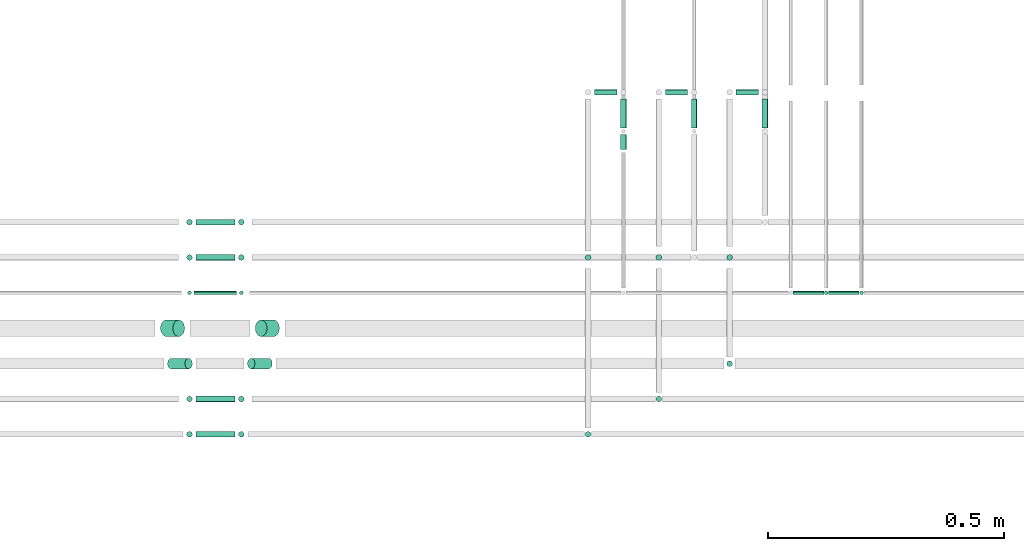
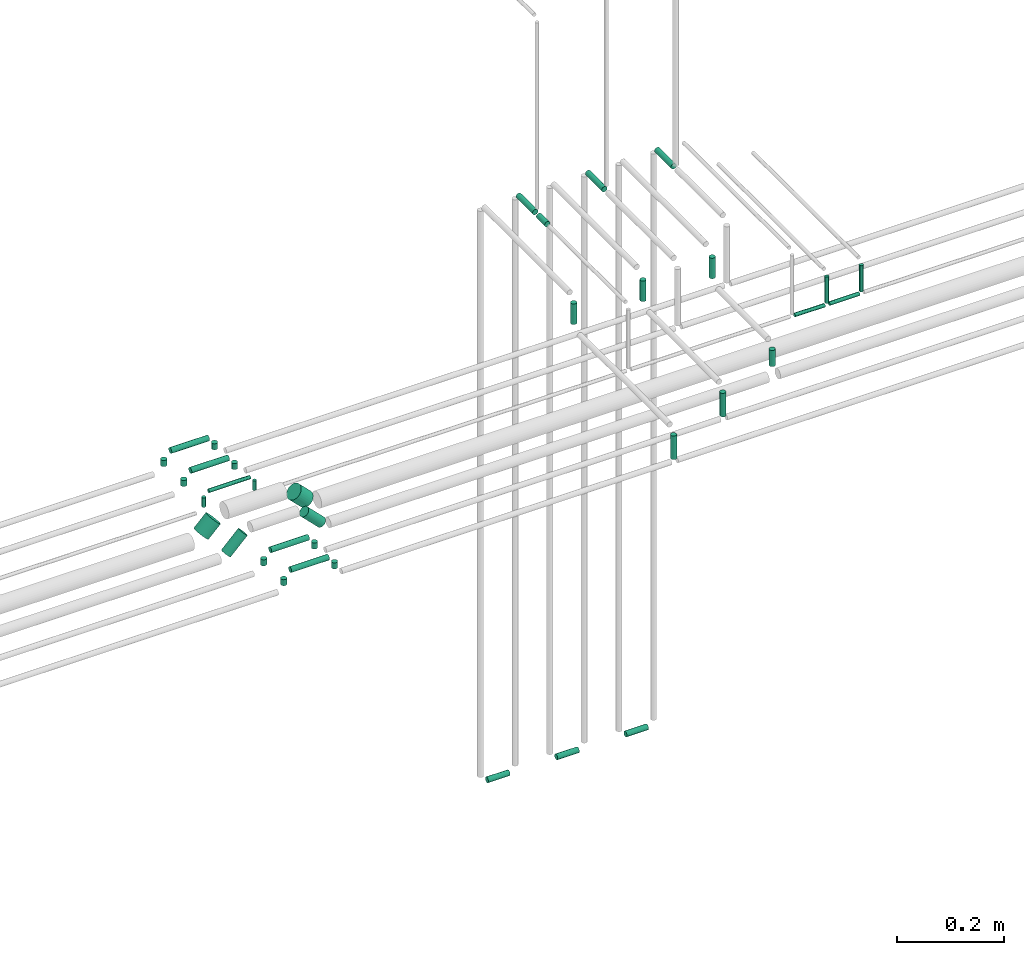
# One storey, part 270 of 331: 36 flow segments.
"""IFC2X3 building model written with IfcOpenShell, lengths in millimetres."""

from ifc_helpers import new_model, entity, si_unit, converted_unit, derived_unit, direction, frame, frame_2d, origin, origin_2d_with_axis, place, context, subcontext, project, spatial, circle, extrude, type_object, element, save


model = new_model("IFC2X3")

# Units and contexts
model_context = context("Model", 3, precision=0.01, world=origin(), true_north=direction((6.12303176911189e-17, 1.0)))
body_context = subcontext(model_context, "Body", "Model", "MODEL_VIEW")
ifc_project = project(units=[si_unit("LENGTHUNIT", "METRE", prefix="MILLI"), si_unit("AREAUNIT", "SQUARE_METRE"), si_unit("VOLUMEUNIT", "CUBIC_METRE"), converted_unit("PLANEANGLEUNIT", "DEGREE", entity("IfcRatioMeasure", 0.0174532925199433), si_unit("PLANEANGLEUNIT", "RADIAN"), dimensions=[0, 0, 0, 0, 0, 0, 0]), si_unit("MASSUNIT", "GRAM", prefix="KILO"), derived_unit("MASSDENSITYUNIT", [(si_unit("MASSUNIT", "GRAM", prefix="KILO"), 1), (si_unit("LENGTHUNIT", "METRE"), -3)]), derived_unit("MOMENTOFINERTIAUNIT", [(si_unit("LENGTHUNIT", "METRE"), 4)]), si_unit("TIMEUNIT", "SECOND"), si_unit("FREQUENCYUNIT", "HERTZ"), si_unit("THERMODYNAMICTEMPERATUREUNIT", "DEGREE_CELSIUS"), derived_unit("THERMALTRANSMITTANCEUNIT", [(si_unit("MASSUNIT", "GRAM", prefix="KILO"), 1), (si_unit("THERMODYNAMICTEMPERATUREUNIT", "KELVIN"), -1), (si_unit("TIMEUNIT", "SECOND"), -3)]), derived_unit("VOLUMETRICFLOWRATEUNIT", [(si_unit("LENGTHUNIT", "METRE"), 3), (si_unit("TIMEUNIT", "SECOND"), -1)]), derived_unit("MASSFLOWRATEUNIT", [(si_unit("MASSUNIT", "GRAM", prefix="KILO"), 1), (si_unit("TIMEUNIT", "SECOND"), -1)]), derived_unit("ROTATIONALFREQUENCYUNIT", [(si_unit("TIMEUNIT", "SECOND"), -1)]), si_unit("ELECTRICCURRENTUNIT", "AMPERE"), si_unit("ELECTRICVOLTAGEUNIT", "VOLT"), si_unit("POWERUNIT", "WATT"), si_unit("FORCEUNIT", "NEWTON", prefix="KILO"), si_unit("ILLUMINANCEUNIT", "LUX"), si_unit("LUMINOUSFLUXUNIT", "LUMEN"), si_unit("LUMINOUSINTENSITYUNIT", "CANDELA"), derived_unit("USERDEFINED", [(si_unit("MASSUNIT", "GRAM", prefix="KILO"), -1), (si_unit("LENGTHUNIT", "METRE"), -2), (si_unit("TIMEUNIT", "SECOND"), 3), (si_unit("LUMINOUSFLUXUNIT", "LUMEN"), 1)]), derived_unit("LINEARVELOCITYUNIT", [(si_unit("LENGTHUNIT", "METRE"), 1), (si_unit("TIMEUNIT", "SECOND"), -1)]), si_unit("PRESSUREUNIT", "PASCAL"), derived_unit("USERDEFINED", [(si_unit("LENGTHUNIT", "METRE"), -2), (si_unit("MASSUNIT", "GRAM", prefix="KILO"), 1), (si_unit("TIMEUNIT", "SECOND"), -2)]), derived_unit("LINEARFORCEUNIT", [(si_unit("MASSUNIT", "GRAM", prefix="KILO"), 1), (si_unit("LENGTHUNIT", "METRE"), 1), (si_unit("TIMEUNIT", "SECOND"), -2), (si_unit("LENGTHUNIT", "METRE"), -1)]), derived_unit("PLANARFORCEUNIT", [(si_unit("MASSUNIT", "GRAM", prefix="KILO"), 1), (si_unit("LENGTHUNIT", "METRE"), 1), (si_unit("TIMEUNIT", "SECOND"), -2), (si_unit("LENGTHUNIT", "METRE"), -2)])], contexts=[model_context])

# Site, building, storey
site_placement = place(None, frame((0.0, -0.00077364408347762, 0.0)))
site = spatial("IfcSite", under=ifc_project, at=site_placement, CompositionType="ELEMENT")
building_placement = place(site_placement, origin())
building = spatial("IfcBuilding", under=site, at=building_placement, CompositionType="ELEMENT")
storey_placement = place(building_placement, origin())
storey = spatial("IfcBuildingStorey", under=building, at=storey_placement, CompositionType="ELEMENT", Elevation=0.0)

# Flow segments
pipe_segment_type = type_object("IfcPipeSegmentType", PredefinedType="NOTDEFINED")
flow_segment_1_placement = place(building_placement, frame((37561.2598936966, 16317.389397967, 5492.40472776408)))
element("IfcFlowSegment", 1, at=flow_segment_1_placement, inside=storey, type_object=pipe_segment_type, context=body_context, shape_type="SweptSolid", body=[
    extrude(circle(Radius=6.0, at=origin_2d_with_axis()), frame((0.0, 7.5952722359167, 7.59527223591562), z_axis=(1.0, 0.0, 0.0), x_axis=(0.0, -1.0, 0.0)), (0.0, 0.0, 1.0), 47.0000000000066),
])
flow_segment_2_placement = place(building_placement, frame((37614.6646214607, 16249.2993255573, 6817.40472776412)))
element("IfcFlowSegment", 2, at=flow_segment_2_placement, inside=storey, type_object=pipe_segment_type, context=body_context, shape_type="SweptSolid", body=[
    extrude(circle(Radius=6.0, at=frame_2d((0.0, -1.08286712929839e-12), x_axis=(1.0, 0.0))), frame((7.59527223591454, 0.0, 7.59527223591454), z_axis=(0.0, 1.0, 0.0), x_axis=(1.0, 0.0, 0.0)), (0.0, 0.0, 1.0), 61.6853446455513),
])
flow_segment_3_placement = place(storey_placement, frame((37711.2598936966, 16317.389397967, 5492.40472776408)))
element("IfcFlowSegment", 3, at=flow_segment_3_placement, inside=storey, type_object=pipe_segment_type, context=body_context, shape_type="SweptSolid", body=[
    extrude(circle(Radius=6.0, at=origin_2d_with_axis()), frame((0.0, 7.5952722359167, 7.59527223591562), z_axis=(1.0, 0.0, 0.0), x_axis=(0.0, -1.0, 0.0)), (0.0, 0.0, 1.0), 47.0000000000066),
])
flow_segment_4_placement = place(storey_placement, frame((37764.6646214607, 16249.2993255574, 6817.40472776411)))
element("IfcFlowSegment", 4, at=flow_segment_4_placement, inside=storey, type_object=pipe_segment_type, context=body_context, shape_type="SweptSolid", body=[
    extrude(circle(Radius=6.0, at=frame_2d((0.0, -1.08286712929839e-12), x_axis=(1.0, 0.0))), frame((7.59527223591454, 0.0, 7.59527223591454), z_axis=(0.0, 1.0, 0.0), x_axis=(1.0, 0.0, 0.0)), (0.0, 0.0, 1.0), 61.6853446455448),
])
flow_segment_5_placement = place(storey_placement, frame((37861.2598936966, 16317.389397967, 5492.40472776408)))
element("IfcFlowSegment", 5, at=flow_segment_5_placement, inside=storey, type_object=pipe_segment_type, context=body_context, shape_type="SweptSolid", body=[
    extrude(circle(Radius=6.0, at=origin_2d_with_axis()), frame((0.0, 7.5952722359167, 7.59527223591562), z_axis=(1.0, 0.0, 0.0), x_axis=(0.0, -1.0, 0.0)), (0.0, 0.0, 1.0), 47.0000000000066),
])
flow_segment_6_placement = place(storey_placement, frame((37914.6646214607, 16249.2993255574, 6817.40472776411)))
element("IfcFlowSegment", 6, at=flow_segment_6_placement, inside=storey, type_object=pipe_segment_type, context=body_context, shape_type="SweptSolid", body=[
    extrude(circle(Radius=6.0, at=frame_2d((0.0, -1.08286712929839e-12), x_axis=(1.0, 0.0))), frame((7.59527223591454, 0.0, 7.59527223591454), z_axis=(0.0, 1.0, 0.0), x_axis=(1.0, 0.0, 0.0)), (0.0, 0.0, 1.0), 61.6853446455448),
])
flow_segment_7_placement = place(building_placement, frame((37539.6646214607, 15592.3893979671, 6682.0)))
element("IfcFlowSegment", 7, at=flow_segment_7_placement, inside=storey, type_object=pipe_segment_type, context=body_context, shape_type="SweptSolid", body=[
    extrude(circle(Radius=6.0, at=origin_2d_with_axis()), frame((7.59527223591454, 7.5952722359167, 0.0), z_axis=(0.0, 0.0, 1.0), x_axis=(-1.0, 0.0, 0.0)), (0.0, 0.0, 1.0), 54.0000000000007),
])
flow_segment_8_placement = place(storey_placement, frame((37689.6646214607, 15667.389397967, 6682.0)))
element("IfcFlowSegment", 8, at=flow_segment_8_placement, inside=storey, type_object=pipe_segment_type, context=body_context, shape_type="SweptSolid", body=[
    extrude(circle(Radius=6.0, at=origin_2d_with_axis()), frame((7.59527223591454, 7.5952722359167, 0.0), z_axis=(0.0, 0.0, 1.0), x_axis=(-1.0, 0.0, 0.0)), (0.0, 0.0, 1.0), 54.0000000000007),
])
flow_segment_9_placement = place(storey_placement, frame((37839.6646214607, 15742.389397967, 6699.0)))
element("IfcFlowSegment", 9, at=flow_segment_9_placement, inside=storey, type_object=pipe_segment_type, context=body_context, shape_type="SweptSolid", body=[
    extrude(circle(Radius=6.0, at=frame_2d((0.0, -2.16573425859679e-12), x_axis=(1.0, 0.0))), frame((7.59527223591454, 7.59527223591454, 0.0), z_axis=(0.0, 0.0, 1.0), x_axis=(-1.0, 0.0, 0.0)), (0.0, 0.0, 1.0), 36.9999999999981),
])
flow_segment_10_placement = place(building_placement, frame((37539.6646214607, 15967.389397967, 6764.0)))
element("IfcFlowSegment", 10, at=flow_segment_10_placement, inside=storey, type_object=pipe_segment_type, context=body_context, shape_type="SweptSolid", body=[
    extrude(circle(Radius=6.0, at=origin_2d_with_axis()), frame((7.59527223591454, 7.5952722359167, 0.0)), (0.0, 0.0, 1.0), 47.0000000000045),
])
flow_segment_11_placement = place(building_placement, frame((37614.6646214607, 16203.5889523343, 6817.40472776411)))
element("IfcFlowSegment", 11, at=flow_segment_11_placement, inside=storey, type_object=pipe_segment_type, context=body_context, shape_type="SweptSolid", body=[
    extrude(circle(Radius=6.0, at=frame_2d((0.0, -1.08286712929839e-12), x_axis=(1.0, 0.0))), frame((7.59527223591454, 0.0, 7.59527223591454), z_axis=(0.0, 1.0, 0.0), x_axis=(1.0, 0.0, 0.0)), (0.0, 0.0, 1.0), 31.7103732230411),
])
for number, where in (
    (12, (37689.6646214607, 15967.389397967, 6764.0)),
    (13, (37839.6646214607, 15967.389397967, 6764.0)),
):
    element("IfcFlowSegment", number, at=place(storey_placement, frame(where)), inside=storey, type_object=pipe_segment_type, context=body_context, shape_type="SweptSolid", body=[
        extrude(circle(Radius=6.0, at=origin_2d_with_axis()), frame((7.59527223591454, 7.5952722359167, 0.0)), (0.0, 0.0, 1.0), 47.0000000000045),
    ])
flow_segment_12_placement = place(storey_placement, frame((38046.440385921, 15894.389397967, 6680.0)))
element("IfcFlowSegment", 14, at=flow_segment_12_placement, inside=storey, type_object=pipe_segment_type, context=body_context, shape_type="SweptSolid", body=[
    extrude(circle(Radius=4.0, at=origin_2d_with_axis()), frame((5.59527223591499, 5.59527223591499, 0.0), z_axis=(0.0, 0.0, 1.0), x_axis=(-1.0, 0.0, 0.0)), (0.0, 0.0, 1.0), 59.9999999999744),
])
flow_segment_13_placement = place(storey_placement, frame((37982.0356581569, 15894.389397967, 6669.40472776411)))
element("IfcFlowSegment", 15, at=flow_segment_13_placement, inside=storey, type_object=pipe_segment_type, context=body_context, shape_type="SweptSolid", body=[
    extrude(circle(Radius=4.0, at=frame_2d((0.0, -1.08286712929839e-12), x_axis=(1.0, 0.0))), frame((0.0, 5.59527223591499, 5.59527223591499), z_axis=(1.0, 0.0, 0.0), x_axis=(0.0, -1.0, 0.0)), (0.0, 0.0, 1.0), 65.0000000000025),
])
flow_segment_14_placement = place(building_placement, frame((38121.440385921, 15894.389397967, 6680.0)))
element("IfcFlowSegment", 16, at=flow_segment_14_placement, inside=storey, type_object=pipe_segment_type, context=body_context, shape_type="SweptSolid", body=[
    extrude(circle(Radius=4.0, at=origin_2d_with_axis()), frame((5.59527223591499, 5.59527223591499, 0.0), z_axis=(0.0, 0.0, 1.0), x_axis=(-1.0, 0.0, 0.0)), (0.0, 0.0, 1.0), 59.9999999999658),
])
flow_segment_15_placement = place(storey_placement, frame((38057.0356581569, 15894.389397967, 6669.40472776412)))
element("IfcFlowSegment", 17, at=flow_segment_15_placement, inside=storey, type_object=pipe_segment_type, context=body_context, shape_type="SweptSolid", body=[
    extrude(circle(Radius=4.0, at=frame_2d((0.0, -1.08286712929839e-12), x_axis=(1.0, 0.0))), frame((0.0, 5.59527223591282, 5.59527223591499), z_axis=(1.0, 0.0, 0.0), x_axis=(0.0, -1.0, 0.0)), (0.0, 0.0, 1.0), 64.9999999999982),
])
flow_segment_16_placement = place(building_placement, frame((36694.8141440075, 15592.3893979671, 6689.0)))
element("IfcFlowSegment", 18, at=flow_segment_16_placement, inside=storey, type_object=pipe_segment_type, context=body_context, shape_type="SweptSolid", body=[
    extrude(circle(Radius=6.0, at=origin_2d_with_axis()), frame((7.59527223591454, 7.5952722359167, 0.0), z_axis=(0.0, 0.0, 1.0), x_axis=(-1.0, 0.0, 0.0)), (0.0, 0.0, 1.0), 13.8563068993709),
])
flow_segment_17_placement = place(building_placement, frame((36716.4094162434, 15592.3893979671, 6709.26103466345)))
element("IfcFlowSegment", 19, at=flow_segment_17_placement, inside=storey, type_object=pipe_segment_type, context=body_context, shape_type="SweptSolid", body=[
    extrude(circle(Radius=6.0, at=frame_2d((0.0, -1.08286712929839e-12), x_axis=(1.0, 0.0))), frame((0.0, 7.59527223592103, 7.59527223591454), z_axis=(1.0, 0.0, 0.0), x_axis=(0.0, -1.0, 0.0)), (0.0, 0.0, 1.0), 81.999999999977),
])
flow_segment_18_placement = place(building_placement, frame((36804.8141440075, 15592.3893979671, 6689.0)))
element("IfcFlowSegment", 20, at=flow_segment_18_placement, inside=storey, type_object=pipe_segment_type, context=body_context, shape_type="SweptSolid", body=[
    extrude(circle(Radius=6.0, at=frame_2d((0.0, 2.16573425859679e-12), x_axis=(1.0, 0.0))), frame((7.59527223591454, 7.59527223591887, 0.0), z_axis=(0.0, 0.0, 1.0), x_axis=(-1.0, 0.0, 0.0)), (0.0, 0.0, 1.0), 13.8563068993655),
])
flow_segment_19_placement = place(storey_placement, frame((36694.8141440075, 15667.3893979671, 6689.0)))
element("IfcFlowSegment", 21, at=flow_segment_19_placement, inside=storey, type_object=pipe_segment_type, context=body_context, shape_type="SweptSolid", body=[
    extrude(circle(Radius=6.0, at=origin_2d_with_axis()), frame((7.59527223591454, 7.5952722359167, 0.0), z_axis=(0.0, 0.0, 1.0), x_axis=(-1.0, 0.0, 0.0)), (0.0, 0.0, 1.0), 13.8563068993709),
])
flow_segment_20_placement = place(storey_placement, frame((36716.4094162434, 15667.3893979671, 6709.26103466345)))
element("IfcFlowSegment", 22, at=flow_segment_20_placement, inside=storey, type_object=pipe_segment_type, context=body_context, shape_type="SweptSolid", body=[
    extrude(circle(Radius=6.0, at=frame_2d((0.0, -1.08286712929839e-12), x_axis=(1.0, 0.0))), frame((0.0, 7.59527223592103, 7.59527223591454), z_axis=(1.0, 0.0, 0.0), x_axis=(0.0, -1.0, 0.0)), (0.0, 0.0, 1.0), 81.999999999977),
])
flow_segment_21_placement = place(storey_placement, frame((36804.8141440075, 15667.3893979671, 6689.0)))
element("IfcFlowSegment", 23, at=flow_segment_21_placement, inside=storey, type_object=pipe_segment_type, context=body_context, shape_type="SweptSolid", body=[
    extrude(circle(Radius=6.0, at=frame_2d((0.0, 2.16573425859679e-12), x_axis=(1.0, 0.0))), frame((7.59527223591454, 7.59527223591887, 0.0), z_axis=(0.0, 0.0, 1.0), x_axis=(-1.0, 0.0, 0.0)), (0.0, 0.0, 1.0), 13.8563068993655),
])
flow_segment_22_placement = place(building_placement, frame((36840.3773294962, 15805.889397967, 6670.92985402991)))
element("IfcFlowSegment", 24, at=flow_segment_22_placement, inside=storey, type_object=pipe_segment_type, context=body_context, shape_type="SweptSolid", body=[
    extrude(circle(Radius=17.5, at=frame_2d((0.0, 7.65702690250587e-13), x_axis=(1.0, 0.0))), frame((40.1325918105774, 19.0952722359163, 13.9696409066762), z_axis=(-0.707106781186255, 0.0, 0.70710678118684), x_axis=(0.0, 1.0, 0.0)), (0.0, 0.0, 1.0), 37.0000000000018),
])
flow_segment_23_placement = place(building_placement, frame((36639.4153887191, 15805.889397967, 6670.92985402991)))
element("IfcFlowSegment", 25, at=flow_segment_23_placement, inside=storey, type_object=pipe_segment_type, context=body_context, shape_type="SweptSolid", body=[
    extrude(circle(Radius=17.5, at=origin_2d_with_axis()), frame((13.9696409066848, 19.0952722359163, 13.9696409066751), z_axis=(0.70710678118624, 0.0, 0.707106781186855), x_axis=(0.0, 1.0, 0.0)), (0.0, 0.0, 1.0), 37.0000000000025),
])
flow_segment_24_placement = place(building_placement, frame((36823.9024557621, 15737.389397967, 6671.9905142017)))
element("IfcFlowSegment", 26, at=flow_segment_24_placement, inside=storey, type_object=pipe_segment_type, context=body_context, shape_type="SweptSolid", body=[
    extrude(circle(Radius=11.0, at=origin_2d_with_axis()), frame((46.1429994506632, 12.5952722359156, 9.3734468289679), z_axis=(-0.707106781186412, 0.0, 0.707106781186683), x_axis=(0.0, 1.0, 0.0)), (0.0, 0.0, 1.0), 52.0000000000042),
])
flow_segment_25_placement = place(building_placement, frame((36654.404981079, 15737.389397967, 6671.9905142017)))
element("IfcFlowSegment", 27, at=flow_segment_25_placement, inside=storey, type_object=pipe_segment_type, context=body_context, shape_type="SweptSolid", body=[
    extrude(circle(Radius=11.0, at=origin_2d_with_axis()), frame((9.37344682897115, 12.5952722359156, 9.3734468289679), z_axis=(0.707106781186402, 0.0, 0.707106781186693), x_axis=(0.0, 1.0, 0.0)), (0.0, 0.0, 1.0), 51.999999999999),
])
flow_segment_26_placement = place(storey_placement, frame((36696.8141440075, 15894.389397967, 6685.0)))
element("IfcFlowSegment", 28, at=flow_segment_26_placement, inside=storey, type_object=pipe_segment_type, context=body_context, shape_type="SweptSolid", body=[
    extrude(circle(Radius=4.0, at=origin_2d_with_axis()), frame((5.59527223591499, 5.59527223591499, 0.0), z_axis=(0.0, 0.0, 1.0), x_axis=(-1.0, 0.0, 0.0)), (0.0, 0.0, 1.0), 21.8563068993702),
])
flow_segment_27_placement = place(storey_placement, frame((36712.4094162434, 15894.389397967, 6711.26103466345)))
element("IfcFlowSegment", 29, at=flow_segment_27_placement, inside=storey, type_object=pipe_segment_type, context=body_context, shape_type="SweptSolid", body=[
    extrude(circle(Radius=4.0, at=frame_2d((0.0, -1.08286712929839e-12), x_axis=(1.0, 0.0))), frame((0.0, 5.59527223591932, 5.59527223591499), z_axis=(1.0, 0.0, 0.0), x_axis=(0.0, -1.0, 0.0)), (0.0, 0.0, 1.0), 89.9999999999752),
])
flow_segment_28_placement = place(storey_placement, frame((36806.8141440075, 15894.389397967, 6685.0)))
element("IfcFlowSegment", 30, at=flow_segment_28_placement, inside=storey, type_object=pipe_segment_type, context=body_context, shape_type="SweptSolid", body=[
    extrude(circle(Radius=4.0, at=origin_2d_with_axis()), frame((5.59527223591499, 5.59527223591499, 0.0), z_axis=(0.0, 0.0, 1.0), x_axis=(-1.0, 0.0, 0.0)), (0.0, 0.0, 1.0), 21.8563068993658),
])
flow_segment_29_placement = place(storey_placement, frame((36694.8141440075, 15967.389397967, 6689.0)))
element("IfcFlowSegment", 31, at=flow_segment_29_placement, inside=storey, type_object=pipe_segment_type, context=body_context, shape_type="SweptSolid", body=[
    extrude(circle(Radius=6.0, at=origin_2d_with_axis()), frame((7.59527223591454, 7.5952722359167, 0.0), z_axis=(0.0, 0.0, 1.0), x_axis=(-1.0, 0.0, 0.0)), (0.0, 0.0, 1.0), 13.8563068993709),
])
flow_segment_30_placement = place(storey_placement, frame((36716.4094162434, 15967.389397967, 6709.26103466345)))
element("IfcFlowSegment", 32, at=flow_segment_30_placement, inside=storey, type_object=pipe_segment_type, context=body_context, shape_type="SweptSolid", body=[
    extrude(circle(Radius=6.0, at=frame_2d((0.0, -1.08286712929839e-12), x_axis=(1.0, 0.0))), frame((0.0, 7.59527223592103, 7.59527223591454), z_axis=(1.0, 0.0, 0.0), x_axis=(0.0, -1.0, 0.0)), (0.0, 0.0, 1.0), 81.999999999977),
])
flow_segment_31_placement = place(storey_placement, frame((36804.8141440075, 15967.389397967, 6689.0)))
element("IfcFlowSegment", 33, at=flow_segment_31_placement, inside=storey, type_object=pipe_segment_type, context=body_context, shape_type="SweptSolid", body=[
    extrude(circle(Radius=6.0, at=origin_2d_with_axis()), frame((7.59527223591454, 7.5952722359167, 0.0), z_axis=(0.0, 0.0, 1.0), x_axis=(-1.0, 0.0, 0.0)), (0.0, 0.0, 1.0), 13.8563068993655),
])
flow_segment_32_placement = place(storey_placement, frame((36694.8141440075, 16042.389397967, 6689.0)))
element("IfcFlowSegment", 34, at=flow_segment_32_placement, inside=storey, type_object=pipe_segment_type, context=body_context, shape_type="SweptSolid", body=[
    extrude(circle(Radius=6.0, at=origin_2d_with_axis()), frame((7.59527223591454, 7.5952722359167, 0.0), z_axis=(0.0, 0.0, 1.0), x_axis=(-1.0, 0.0, 0.0)), (0.0, 0.0, 1.0), 13.8563068993709),
])
flow_segment_33_placement = place(storey_placement, frame((36716.4094162434, 16042.389397967, 6709.26103466345)))
element("IfcFlowSegment", 35, at=flow_segment_33_placement, inside=storey, type_object=pipe_segment_type, context=body_context, shape_type="SweptSolid", body=[
    extrude(circle(Radius=6.0, at=frame_2d((0.0, -1.08286712929839e-12), x_axis=(1.0, 0.0))), frame((0.0, 7.59527223592103, 7.59527223591454), z_axis=(1.0, 0.0, 0.0), x_axis=(0.0, -1.0, 0.0)), (0.0, 0.0, 1.0), 81.999999999977),
])
flow_segment_34_placement = place(storey_placement, frame((36804.8141440075, 16042.389397967, 6689.0)))
element("IfcFlowSegment", 36, at=flow_segment_34_placement, inside=storey, type_object=pipe_segment_type, context=body_context, shape_type="SweptSolid", body=[
    extrude(circle(Radius=6.0, at=origin_2d_with_axis()), frame((7.59527223591454, 7.5952722359167, 0.0), z_axis=(0.0, 0.0, 1.0), x_axis=(-1.0, 0.0, 0.0)), (0.0, 0.0, 1.0), 13.8563068993655),
])

save(model, "model.ifc")
